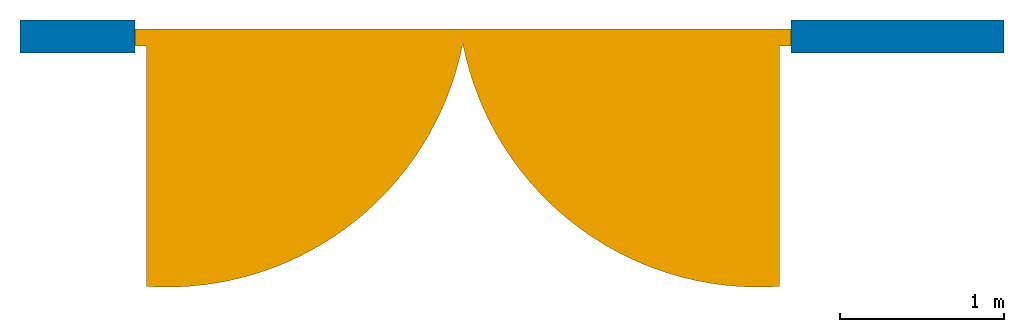
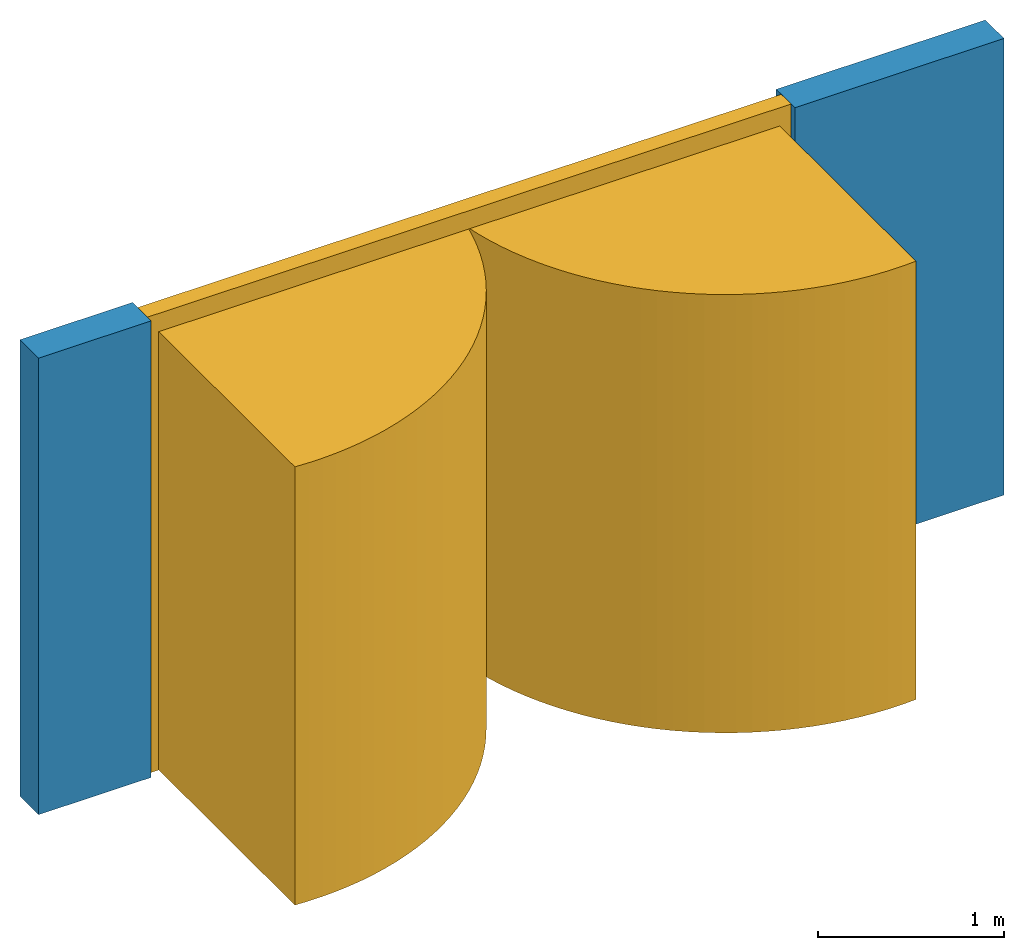
# One storey: 1 door, 1 wall, 1 opening.
"""IFC2X3 building model written with IfcOpenShell, lengths in millimetres."""

from ifc_helpers import new_model, entity, si_unit, converted_unit, derived_unit, direction, frame, frame_2d, origin, origin_2d_with_axis, place, context, subcontext, project, spatial, polyline, circle_curve, parameter, trimmed, segment, composite_curve, rectangle, outline, extrude, source, transform, mapped, material, material_list, layer, layer_set, layer_usage, type_object, type_shapes, element, fill, save


model = new_model("IFC2X3")

# Units and contexts
model_context = context("Model", 3, precision=0.01, world=origin(), true_north=direction((6.12303176911189e-17, 1.0)))
context_of_model = context(None, 3, precision=0.01, world=origin(), true_north=direction((6.12303176911189e-17, 1.0)))
body_context = subcontext(model_context, "Body", "Model", "MODEL_VIEW")
ifc_project = project(units=[si_unit("LENGTHUNIT", "METRE", prefix="MILLI"), si_unit("AREAUNIT", "SQUARE_METRE"), si_unit("VOLUMEUNIT", "CUBIC_METRE"), converted_unit("PLANEANGLEUNIT", "DEGREE", entity("IfcRatioMeasure", 0.0174532925199433), si_unit("PLANEANGLEUNIT", "RADIAN"), dimensions=[0, 0, 0, 0, 0, 0, 0]), si_unit("MASSUNIT", "GRAM", prefix="KILO"), si_unit("TIMEUNIT", "SECOND"), si_unit("FREQUENCYUNIT", "HERTZ"), si_unit("THERMODYNAMICTEMPERATUREUNIT", "DEGREE_CELSIUS"), derived_unit("THERMALTRANSMITTANCEUNIT", [(si_unit("MASSUNIT", "GRAM", prefix="KILO"), 1), (si_unit("THERMODYNAMICTEMPERATUREUNIT", "KELVIN"), -1), (si_unit("TIMEUNIT", "SECOND"), -3)]), derived_unit("VOLUMETRICFLOWRATEUNIT", [(si_unit("LENGTHUNIT", "METRE"), 3), (si_unit("TIMEUNIT", "SECOND"), -1)]), si_unit("ELECTRICCURRENTUNIT", "AMPERE"), si_unit("ELECTRICVOLTAGEUNIT", "VOLT"), si_unit("POWERUNIT", "WATT"), si_unit("FORCEUNIT", "NEWTON", prefix="KILO"), si_unit("ILLUMINANCEUNIT", "LUX"), si_unit("LUMINOUSFLUXUNIT", "LUMEN"), si_unit("LUMINOUSINTENSITYUNIT", "CANDELA"), si_unit("PRESSUREUNIT", "PASCAL")], contexts=[model_context, context_of_model])

# Site, building, storey
site_placement = place(None, origin())
site = spatial("IfcSite", under=ifc_project, at=site_placement, CompositionType="ELEMENT")
building_placement = place(site_placement, origin())
building = spatial("IfcBuilding", under=site, at=building_placement, CompositionType="ELEMENT")
storey_placement = place(building_placement, origin())
storey = spatial("IfcBuildingStorey", under=building, at=storey_placement, CompositionType="ELEMENT", Elevation=0.0)

# Wall, opening, door
ifc_material_1 = material()
ifc_layer = layer(ifc_material_1, 200.0)
ifc_layer_set = layer_set([ifc_layer])
ifc_layer_usage = layer_usage(ifc_layer_set, "AXIS2", "NEGATIVE", 100.0)
wall_type = type_object("IfcWallType", PredefinedType="STANDARD", material=ifc_layer_set)
wall_placement = place(storey_placement, frame((-30147.0958388037, 10047.082659008, 0.0)))
wall = element("IfcWallStandardCase", 1, at=wall_placement, inside=storey, type_object=wall_type, material=ifc_layer_usage, context=body_context, shape_type="SweptSolid", body=[
    extrude(rectangle(XDim=6000.0, YDim=199.999999999998, at=frame_2d((3000.0, 6.96331881044898e-13), x_axis=(-1.0, 0.0))), origin(), (0.0, 0.0, 1.0), 3000.0),
])
opening_placement = place(wall_placement, frame((30147.0958388037, -10047.082659008, 0.0)))
opening = element("IfcOpeningElement", 2, at=opening_placement, cuts=wall, ObjectType="Opening", context=body_context, shape_type="SweptSolid", body=[
    extrude(rectangle(XDim=2999.99999999998, YDim=4000.0, at=origin_2d_with_axis()), frame((-27447.0958388037, 9947.082659008, 1500.0), z_axis=(0.0, 1.0, 0.0), x_axis=(0.0, 0.0, -1.0)), (0.0, 0.0, 1.0), 200.0),
])
ifc_material_2 = material()
ifc_material_3 = material()
ifc_material_4 = material()
ifc_material_list_1 = material_list([ifc_material_2, ifc_material_3, ifc_material_4])
ifc_material_list_2 = material_list([ifc_material_2, ifc_material_3, ifc_material_4])
door_style = type_object("IfcDoorStyle", ConstructionType="NOTDEFINED", OperationType="NOTDEFINED", ParameterTakesPrecedence=False, Sizeable=False, material=ifc_material_list_2)
shared_shape = source(origin(), body_context, "Body", "SweptSolid", [
    extrude(outline(composite_curve([segment(polyline([(-1286.46660643626, -493.242192533162), (643.233303218133, -493.242192533162)]), True, "CONTINUOUS"), segment(polyline([(643.233303218133, -493.242192533162), (643.233303218133, 986.484385066325)]), True, "CONTINUOUS"), segment(trimmed(circle_curve(frame_2d((517.575299360933, -847.762593588191), x_axis=(1.0, 0.0)), 1838.54614101376), [parameter(86.080984774204)], [parameter(168.882218859217)], True, "PARAMETER"), True, "CONTINUOUS")], self_intersect=False)), frame((3286.40672302689, 638.242192533148, 0.0)), (0.0, 0.0, 1.0), 2879.99999999999),
    extrude(outline(composite_curve([segment(polyline([(-986.467921024304, -643.353294469789), (493.233960512146, -643.353294469789)]), True, "CONTINUOUS"), segment(polyline([(493.233960512146, -643.353294469789), (493.233960512146, 1286.70658893957)]), True, "CONTINUOUS"), segment(trimmed(circle_curve(frame_2d((847.754361567179, -517.335316857613), x_axis=(0.0, 1.0)), 1838.54614101376), [parameter(11.117781140783)], [parameter(93.9302596851932)], True, "PARAMETER"), True, "CONTINUOUS")], self_intersect=False)), frame((713.353294469788, 638.233960512132, 0.0), z_axis=(0.0, 0.0, 1.0), x_axis=(0.0, -1.0, 0.0)), (0.0, 0.0, 1.0), 2879.99999999999),
    extrude(outline(polyline([(-1530.0, -2000.0), (1470.0, -2000.0), (1470.0, -1930.0), (-1410.0, -1930.0), (-1410.0, 1930.0), (1470.0, 1930.0), (1470.0, 2000.0), (-1530.0, 2000.0), (-1530.0, -2000.0)])), frame((2000.0, 55.0, 1470.0), z_axis=(0.0, 1.0, 0.0), x_axis=(0.0, 0.0, -1.0)), (0.0, 0.0, 1.0), 104.797197597327),
    extrude(rectangle(XDim=1100.0, YDim=90.0, at=origin_2d_with_axis()), frame((1391.70053223683, 100.0, 0.0), z_axis=(0.0, 0.0, 1.0), x_axis=(-1.0, 0.0, 0.0)), (0.0, 0.0, 1.0), 2000.0),
    extrude(rectangle(XDim=90.0000000000019, YDim=1930.0, at=frame_2d((1.21147536447097e-12, 0.0), x_axis=(1.0, 0.0))), frame((2965.0, 100.0, 0.0), z_axis=(0.0, 0.0, 1.0), x_axis=(0.0, -1.0, 0.0)), (0.0, 0.0, 1.0), 2879.99999999999),
    extrude(rectangle(XDim=1929.64002624503, YDim=90.0, at=origin_2d_with_axis()), frame((1035.17998687748, 100.0, 0.0), z_axis=(0.0, 0.0, 1.0), x_axis=(-1.0, 0.0, 0.0)), (0.0, 0.0, 1.0), 2879.99999999999),
    extrude(rectangle(XDim=90.0, YDim=200.0, at=origin_2d_with_axis()), frame((2196.81592365038, 100.0, 57.2337241711716), z_axis=(0.0, 0.0, 1.0), x_axis=(0.0, 1.0, 0.0)), (0.0, 0.0, 1.0), 200.000000000001),
])
type_shapes(door_style, [shared_shape])
door_placement = place(opening_placement, frame((-25447.0958388037, 10147.082659008, 0.0), z_axis=(0.0, 0.0, 1.0), x_axis=(-1.0, 0.0, 0.0)))
door = element("IfcDoor", 3, at=door_placement, inside=storey, type_object=door_style, material=ifc_material_list_1, OverallHeight=4000.0, OverallWidth=2999.99999999998, context=body_context, shape_type="MappedRepresentation", body=[
    mapped(shared_shape, transform((0.0, 0.0, 0.0), scale=1.0)),
])
fill(opening, door)

save(model, "model.ifc")
